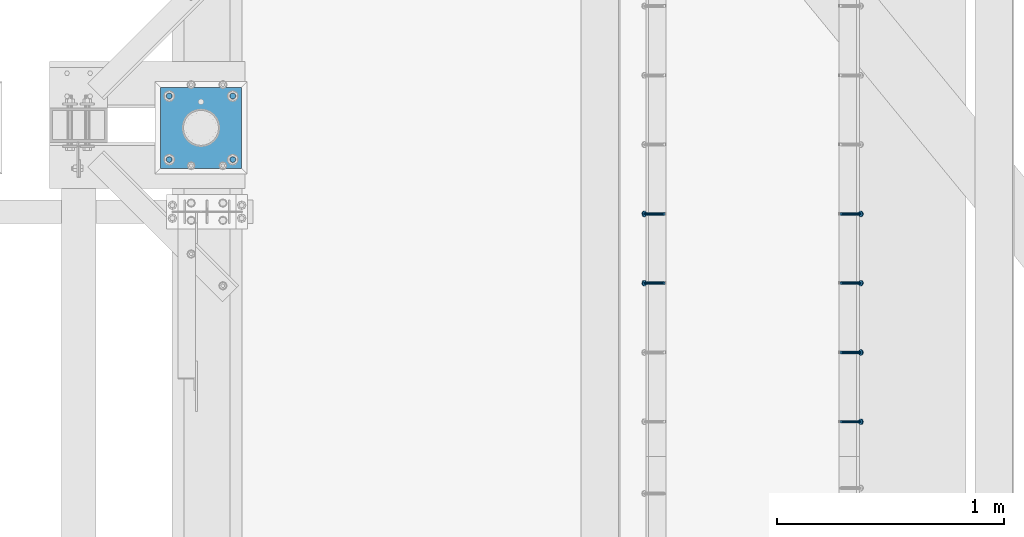
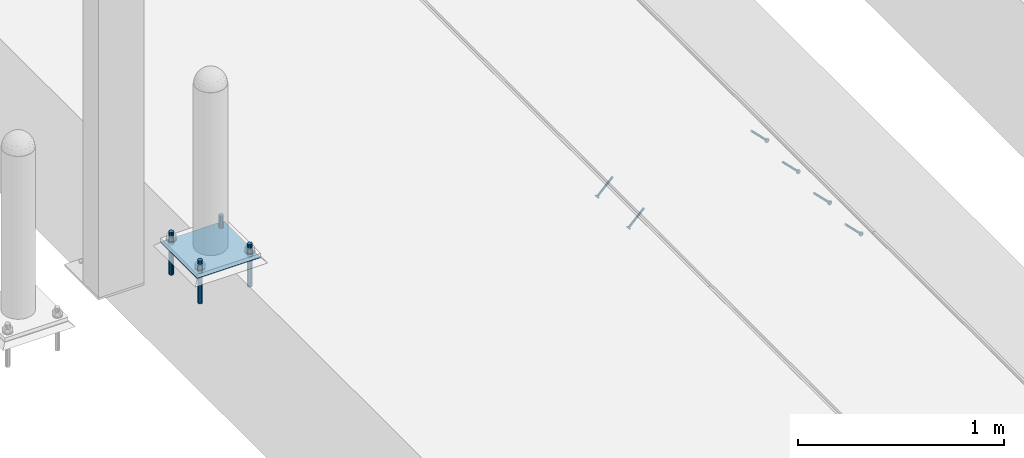
# One storey, part 2035 of 3843: 6 members, 5 beams, 3 elements without a shape of their own.
"""IFC2X3 building model written with IfcOpenShell, lengths in millimetres."""

from ifc_helpers import new_model, si_unit, frame, origin_with_axes, place, context, subcontext, project, spatial, faceted_brep, material, type_object, element, aggregate, save


model = new_model("IFC2X3")

# Units and contexts
model_context = context("Model", 3, precision=1e-05, world=origin_with_axes())
body_context = subcontext(model_context, "Body", "Model", "MODEL_VIEW")
ifc_project = project(units=[si_unit("LENGTHUNIT", "METRE", prefix="MILLI"), si_unit("AREAUNIT", "SQUARE_METRE"), si_unit("VOLUMEUNIT", "CUBIC_METRE"), si_unit("MASSUNIT", "GRAM", prefix="KILO"), si_unit("TIMEUNIT", "SECOND"), si_unit("PLANEANGLEUNIT", "RADIAN"), si_unit("SOLIDANGLEUNIT", "STERADIAN"), si_unit("THERMODYNAMICTEMPERATUREUNIT", "DEGREE_CELSIUS"), si_unit("LUMINOUSINTENSITYUNIT", "LUMEN")], contexts=[model_context])

# Site, building, storey
site_placement = place(None, origin_with_axes())
site = spatial("IfcSite", under=ifc_project, at=site_placement, CompositionType="ELEMENT")
building_placement = place(site_placement, origin_with_axes())
building = spatial("IfcBuilding", under=site, at=building_placement, Name="Undefined", CompositionType="ELEMENT")
storey_placement = place(building_placement, origin_with_axes())
storey = spatial("IfcBuildingStorey", under=building, at=storey_placement, Name="Undefined", CompositionType="ELEMENT", Elevation=0.0)

# Assembly, members
assembly_1_placement = place(storey_placement, origin_with_axes())
assembly_1 = element("IfcElementAssembly", 1, at=assembly_1_placement, inside=storey, Name="EMBED_ANGLE", AssemblyPlace="NOTDEFINED", PredefinedType="RIGID_FRAME")
ifc_material_1 = material(Name="STEEL/A108")
member_type = type_object("IfcMemberType", PredefinedType="NOTDEFINED")
member_1_placement = place(assembly_1_placement, frame((44851.3834999999, 28806.775189209, 30456.1875), z_axis=(0.0, 1.0, 0.0), x_axis=(0.707106781186548, 0.0, -0.707106781186548)))
member_1 = element("IfcMember", 2, at=member_1_placement, type_object=member_type, material=ifc_material_1, Name="HEADED STUD ANCHOR", context=body_context, shape_type="Brep", body=[
    faceted_brep([(7.27595761418343e-12, -3.18000006675175, 5.5), (0.0, -5.49999999998363, 3.1800000667572), (118.110000000976, -5.49999999999091, 3.1800000667572), (118.110000000983, -3.18000006675175, 5.5), (0.0, -6.3499999046162, 0.0), (118.110000000968, -6.34999990461256, 0.0), (0.0, -5.49999999998363, -3.1800000667572), (118.110000000976, -5.49999999999091, -3.1800000667572), (7.27595761418343e-12, -3.18000006675175, -5.5), (118.110000000983, -3.18000006675175, -5.5), (7.27595761418343e-12, -1.81898940354586e-12, -6.34999990463257), (118.110000000968, -1.81898940354586e-12, -6.34999990463257), (0.0, 3.18000006675175, -5.5), (118.110000000968, 3.18000006674811, -5.5), (7.27595761418343e-12, 5.49999999998363, -3.1800000667572), (118.110000000983, 5.49999999998363, -3.1800000667572), (7.27595761418343e-12, 6.3499999046162, 0.0), (118.110000000976, 6.34999990461256, 0.0), (7.27595761418343e-12, 5.49999999998363, 3.1800000667572), (118.110000000983, 5.49999999998363, 3.1800000667572), (0.0, 3.18000006675175, 5.5), (118.110000000968, 3.18000006674811, 5.5), (7.27595761418343e-12, -1.81898940354586e-12, 6.34999990463257), (118.110000000968, -1.81898940354586e-12, 6.34999990463257), (120.650000000991, -10.9899997710909, 6.34999990463257), (120.650000000998, -6.34000015257152, 10.9899997711182), (120.650000000991, -12.6999998092379, 0.0), (120.650000000991, -10.9899997710909, -6.34999990463257), (120.650000000998, -6.34000015257152, -10.9899997711182), (120.650000000991, -1.81898940354586e-12, -12.6899995803833), (120.650000000991, 6.34000015257152, -10.9899997711182), (120.650000000998, 10.9899997710909, -6.34999990463257), (120.650000000991, 12.6999998092342, 0.0), (120.650000000998, 10.9899997710909, 6.34999990463257), (120.650000000991, 6.34000015257152, 10.9899997711182), (120.650000000991, -1.81898940354586e-12, 12.6899995803833), (127.000000001048, -10.9899997710945, 6.34999990463257), (127.000000001048, -6.34000015257152, 10.9899997711182), (127.000000001048, -12.6999998092342, 0.0), (127.000000001048, -10.9899997710945, -6.34999990463257), (127.000000001048, -6.34000015257152, -10.9899997711182), (127.000000001048, 1.81898940354586e-12, -12.6899995803833), (127.000000001048, 6.34000015256788, -10.9899997711182), (127.000000001048, 10.9899997710909, -6.34999990463257), (127.000000001048, 12.6999998092379, 0.0), (127.000000001048, 10.9899997710909, 6.34999990463257), (127.000000001048, 6.34000015256788, 10.9899997711182), (127.000000001048, 1.81898940354586e-12, 12.6899995803833)], [[[0, 1, 2, 3]], [[1, 4, 5, 2]], [[4, 6, 7, 5]], [[6, 8, 9, 7]], [[8, 10, 11, 9]], [[10, 12, 13, 11]], [[12, 14, 15, 13]], [[14, 16, 17, 15]], [[16, 18, 19, 17]], [[18, 20, 21, 19]], [[20, 22, 23, 21]], [[22, 0, 3, 23]], [[22, 20, 18, 16, 14, 12, 10, 8, 6, 4, 1, 0]], [[3, 2, 24, 25]], [[2, 5, 26, 24]], [[5, 7, 27, 26]], [[7, 9, 28, 27]], [[9, 11, 29, 28]], [[11, 13, 30, 29]], [[13, 15, 31, 30]], [[15, 17, 32, 31]], [[17, 19, 33, 32]], [[19, 21, 34, 33]], [[21, 23, 35, 34]], [[23, 3, 25, 35]], [[25, 24, 36, 37]], [[24, 26, 38, 36]], [[26, 27, 39, 38]], [[27, 28, 40, 39]], [[28, 29, 41, 40]], [[29, 30, 42, 41]], [[30, 31, 43, 42]], [[31, 32, 44, 43]], [[32, 33, 45, 44]], [[33, 34, 46, 45]], [[34, 35, 47, 46]], [[35, 25, 37, 47]], [[38, 39, 40, 41, 42, 43, 44, 45, 46, 47, 37, 36]]]),
])
member_2_placement = place(assembly_1_placement, frame((44851.3834999999, 29111.575189209, 30456.1875), z_axis=(0.0, 1.0, 0.0), x_axis=(0.707106781186548, 0.0, -0.707106781186548)))
member_2 = element("IfcMember", 3, at=member_2_placement, type_object=member_type, material=ifc_material_1, Name="HEADED STUD ANCHOR", context=body_context, shape_type="Brep", body=[
    faceted_brep([(7.27595761418343e-12, -3.18000006675175, 5.5), (0.0, -5.49999999998363, 3.1800000667572), (118.110000000976, -5.49999999999091, 3.1800000667572), (118.110000000983, -3.18000006675175, 5.5), (0.0, -6.3499999046162, 0.0), (118.110000000968, -6.34999990461256, 0.0), (0.0, -5.49999999998363, -3.1800000667572), (118.110000000976, -5.49999999999091, -3.1800000667572), (7.27595761418343e-12, -3.18000006675175, -5.5), (118.110000000983, -3.18000006675175, -5.5), (7.27595761418343e-12, -1.81898940354586e-12, -6.34999990463257), (118.110000000968, -1.81898940354586e-12, -6.34999990463257), (0.0, 3.18000006675175, -5.5), (118.110000000968, 3.18000006674811, -5.5), (7.27595761418343e-12, 5.49999999998363, -3.1800000667572), (118.110000000983, 5.49999999998363, -3.1800000667572), (7.27595761418343e-12, 6.3499999046162, 0.0), (118.110000000976, 6.34999990461256, 0.0), (7.27595761418343e-12, 5.49999999998363, 3.1800000667572), (118.110000000983, 5.49999999998363, 3.1800000667572), (0.0, 3.18000006675175, 5.5), (118.110000000968, 3.18000006674811, 5.5), (7.27595761418343e-12, -1.81898940354586e-12, 6.34999990463257), (118.110000000968, -1.81898940354586e-12, 6.34999990463257), (120.650000000991, -10.9899997710909, 6.34999990463257), (120.650000000998, -6.34000015257152, 10.9899997711182), (120.650000000991, -12.6999998092379, 0.0), (120.650000000991, -10.9899997710909, -6.34999990463257), (120.650000000998, -6.34000015257152, -10.9899997711182), (120.650000000991, -1.81898940354586e-12, -12.6899995803833), (120.650000000991, 6.34000015257152, -10.9899997711182), (120.650000000998, 10.9899997710909, -6.34999990463257), (120.650000000991, 12.6999998092342, 0.0), (120.650000000998, 10.9899997710909, 6.34999990463257), (120.650000000991, 6.34000015257152, 10.9899997711182), (120.650000000991, -1.81898940354586e-12, 12.6899995803833), (127.000000001048, -10.9899997710945, 6.34999990463257), (127.000000001048, -6.34000015257152, 10.9899997711182), (127.000000001048, -12.6999998092342, 0.0), (127.000000001048, -10.9899997710945, -6.34999990463257), (127.000000001048, -6.34000015257152, -10.9899997711182), (127.000000001048, 1.81898940354586e-12, -12.6899995803833), (127.000000001048, 6.34000015256788, -10.9899997711182), (127.000000001048, 10.9899997710909, -6.34999990463257), (127.000000001048, 12.6999998092379, 0.0), (127.000000001048, 10.9899997710909, 6.34999990463257), (127.000000001048, 6.34000015256788, 10.9899997711182), (127.000000001048, 1.81898940354586e-12, 12.6899995803833)], [[[0, 1, 2, 3]], [[1, 4, 5, 2]], [[4, 6, 7, 5]], [[6, 8, 9, 7]], [[8, 10, 11, 9]], [[10, 12, 13, 11]], [[12, 14, 15, 13]], [[14, 16, 17, 15]], [[16, 18, 19, 17]], [[18, 20, 21, 19]], [[20, 22, 23, 21]], [[22, 0, 3, 23]], [[22, 20, 18, 16, 14, 12, 10, 8, 6, 4, 1, 0]], [[3, 2, 24, 25]], [[2, 5, 26, 24]], [[5, 7, 27, 26]], [[7, 9, 28, 27]], [[9, 11, 29, 28]], [[11, 13, 30, 29]], [[13, 15, 31, 30]], [[15, 17, 32, 31]], [[17, 19, 33, 32]], [[19, 21, 34, 33]], [[21, 23, 35, 34]], [[23, 3, 25, 35]], [[25, 24, 36, 37]], [[24, 26, 38, 36]], [[26, 27, 39, 38]], [[27, 28, 40, 39]], [[28, 29, 41, 40]], [[29, 30, 42, 41]], [[30, 31, 43, 42]], [[31, 32, 44, 43]], [[32, 33, 45, 44]], [[33, 34, 46, 45]], [[34, 35, 47, 46]], [[35, 25, 37, 47]], [[38, 39, 40, 41, 42, 43, 44, 45, 46, 47, 37, 36]]]),
])
member_3_placement = place(assembly_1_placement, frame((44851.3834999999, 29416.375189209, 30456.1875), z_axis=(0.0, 1.0, 0.0), x_axis=(0.707106781186548, 0.0, -0.707106781186548)))
member_3 = element("IfcMember", 4, at=member_3_placement, type_object=member_type, material=ifc_material_1, Name="HEADED STUD ANCHOR", context=body_context, shape_type="Brep", body=[
    faceted_brep([(7.27595761418343e-12, -3.18000006675175, 5.5), (0.0, -5.49999999998363, 3.1800000667572), (118.110000000976, -5.49999999999091, 3.1800000667572), (118.110000000983, -3.18000006675175, 5.5), (0.0, -6.3499999046162, 0.0), (118.110000000968, -6.34999990461256, 0.0), (0.0, -5.49999999998363, -3.1800000667572), (118.110000000976, -5.49999999999091, -3.1800000667572), (7.27595761418343e-12, -3.18000006675175, -5.5), (118.110000000983, -3.18000006675175, -5.5), (7.27595761418343e-12, -1.81898940354586e-12, -6.34999990463257), (118.110000000968, -1.81898940354586e-12, -6.34999990463257), (0.0, 3.18000006675175, -5.5), (118.110000000968, 3.18000006674811, -5.5), (7.27595761418343e-12, 5.49999999998363, -3.1800000667572), (118.110000000983, 5.49999999998363, -3.1800000667572), (7.27595761418343e-12, 6.3499999046162, 0.0), (118.110000000976, 6.34999990461256, 0.0), (7.27595761418343e-12, 5.49999999998363, 3.1800000667572), (118.110000000983, 5.49999999998363, 3.1800000667572), (0.0, 3.18000006675175, 5.5), (118.110000000968, 3.18000006674811, 5.5), (7.27595761418343e-12, -1.81898940354586e-12, 6.34999990463257), (118.110000000968, -1.81898940354586e-12, 6.34999990463257), (120.650000000991, -10.9899997710909, 6.34999990463257), (120.650000000998, -6.34000015257152, 10.9899997711182), (120.650000000991, -12.6999998092379, 0.0), (120.650000000991, -10.9899997710909, -6.34999990463257), (120.650000000998, -6.34000015257152, -10.9899997711182), (120.650000000991, -1.81898940354586e-12, -12.6899995803833), (120.650000000991, 6.34000015257152, -10.9899997711182), (120.650000000998, 10.9899997710909, -6.34999990463257), (120.650000000991, 12.6999998092342, 0.0), (120.650000000998, 10.9899997710909, 6.34999990463257), (120.650000000991, 6.34000015257152, 10.9899997711182), (120.650000000991, -1.81898940354586e-12, 12.6899995803833), (127.000000001048, -10.9899997710945, 6.34999990463257), (127.000000001048, -6.34000015257152, 10.9899997711182), (127.000000001048, -12.6999998092342, 0.0), (127.000000001048, -10.9899997710945, -6.34999990463257), (127.000000001048, -6.34000015257152, -10.9899997711182), (127.000000001048, 1.81898940354586e-12, -12.6899995803833), (127.000000001048, 6.34000015256788, -10.9899997711182), (127.000000001048, 10.9899997710909, -6.34999990463257), (127.000000001048, 12.6999998092379, 0.0), (127.000000001048, 10.9899997710909, 6.34999990463257), (127.000000001048, 6.34000015256788, 10.9899997711182), (127.000000001048, 1.81898940354586e-12, 12.6899995803833)], [[[0, 1, 2, 3]], [[1, 4, 5, 2]], [[4, 6, 7, 5]], [[6, 8, 9, 7]], [[8, 10, 11, 9]], [[10, 12, 13, 11]], [[12, 14, 15, 13]], [[14, 16, 17, 15]], [[16, 18, 19, 17]], [[18, 20, 21, 19]], [[20, 22, 23, 21]], [[22, 0, 3, 23]], [[22, 20, 18, 16, 14, 12, 10, 8, 6, 4, 1, 0]], [[3, 2, 24, 25]], [[2, 5, 26, 24]], [[5, 7, 27, 26]], [[7, 9, 28, 27]], [[9, 11, 29, 28]], [[11, 13, 30, 29]], [[13, 15, 31, 30]], [[15, 17, 32, 31]], [[17, 19, 33, 32]], [[19, 21, 34, 33]], [[21, 23, 35, 34]], [[23, 3, 25, 35]], [[25, 24, 36, 37]], [[24, 26, 38, 36]], [[26, 27, 39, 38]], [[27, 28, 40, 39]], [[28, 29, 41, 40]], [[29, 30, 42, 41]], [[30, 31, 43, 42]], [[31, 32, 44, 43]], [[32, 33, 45, 44]], [[33, 34, 46, 45]], [[34, 35, 47, 46]], [[35, 25, 37, 47]], [[38, 39, 40, 41, 42, 43, 44, 45, 46, 47, 37, 36]]]),
])
member_4_placement = place(assembly_1_placement, frame((44851.3834999999, 29721.175189209, 30456.1875), z_axis=(0.0, 1.0, 0.0), x_axis=(0.707106781186548, 0.0, -0.707106781186548)))
member_4 = element("IfcMember", 5, at=member_4_placement, type_object=member_type, material=ifc_material_1, Name="HEADED STUD ANCHOR", context=body_context, shape_type="Brep", body=[
    faceted_brep([(7.27595761418343e-12, -3.18000006675175, 5.5), (0.0, -5.49999999998363, 3.1800000667572), (118.110000000976, -5.49999999999091, 3.1800000667572), (118.110000000983, -3.18000006675175, 5.5), (0.0, -6.3499999046162, 0.0), (118.110000000968, -6.34999990461256, 0.0), (0.0, -5.49999999998363, -3.1800000667572), (118.110000000976, -5.49999999999091, -3.1800000667572), (7.27595761418343e-12, -3.18000006675175, -5.5), (118.110000000983, -3.18000006675175, -5.5), (7.27595761418343e-12, -1.81898940354586e-12, -6.34999990463257), (118.110000000968, -1.81898940354586e-12, -6.34999990463257), (0.0, 3.18000006675175, -5.5), (118.110000000968, 3.18000006674811, -5.5), (7.27595761418343e-12, 5.49999999998363, -3.1800000667572), (118.110000000983, 5.49999999998363, -3.1800000667572), (7.27595761418343e-12, 6.3499999046162, 0.0), (118.110000000976, 6.34999990461256, 0.0), (7.27595761418343e-12, 5.49999999998363, 3.1800000667572), (118.110000000983, 5.49999999998363, 3.1800000667572), (0.0, 3.18000006675175, 5.5), (118.110000000968, 3.18000006674811, 5.5), (7.27595761418343e-12, -1.81898940354586e-12, 6.34999990463257), (118.110000000968, -1.81898940354586e-12, 6.34999990463257), (120.650000000991, -10.9899997710909, 6.34999990463257), (120.650000000998, -6.34000015257152, 10.9899997711182), (120.650000000991, -12.6999998092379, 0.0), (120.650000000991, -10.9899997710909, -6.34999990463257), (120.650000000998, -6.34000015257152, -10.9899997711182), (120.650000000991, -1.81898940354586e-12, -12.6899995803833), (120.650000000991, 6.34000015257152, -10.9899997711182), (120.650000000998, 10.9899997710909, -6.34999990463257), (120.650000000991, 12.6999998092342, 0.0), (120.650000000998, 10.9899997710909, 6.34999990463257), (120.650000000991, 6.34000015257152, 10.9899997711182), (120.650000000991, -1.81898940354586e-12, 12.6899995803833), (127.000000001048, -10.9899997710945, 6.34999990463257), (127.000000001048, -6.34000015257152, 10.9899997711182), (127.000000001048, -12.6999998092342, 0.0), (127.000000001048, -10.9899997710945, -6.34999990463257), (127.000000001048, -6.34000015257152, -10.9899997711182), (127.000000001048, 1.81898940354586e-12, -12.6899995803833), (127.000000001048, 6.34000015256788, -10.9899997711182), (127.000000001048, 10.9899997710909, -6.34999990463257), (127.000000001048, 12.6999998092379, 0.0), (127.000000001048, 10.9899997710909, 6.34999990463257), (127.000000001048, 6.34000015256788, 10.9899997711182), (127.000000001048, 1.81898940354586e-12, 12.6899995803833)], [[[0, 1, 2, 3]], [[1, 4, 5, 2]], [[4, 6, 7, 5]], [[6, 8, 9, 7]], [[8, 10, 11, 9]], [[10, 12, 13, 11]], [[12, 14, 15, 13]], [[14, 16, 17, 15]], [[16, 18, 19, 17]], [[18, 20, 21, 19]], [[20, 22, 23, 21]], [[22, 0, 3, 23]], [[22, 20, 18, 16, 14, 12, 10, 8, 6, 4, 1, 0]], [[3, 2, 24, 25]], [[2, 5, 26, 24]], [[5, 7, 27, 26]], [[7, 9, 28, 27]], [[9, 11, 29, 28]], [[11, 13, 30, 29]], [[13, 15, 31, 30]], [[15, 17, 32, 31]], [[17, 19, 33, 32]], [[19, 21, 34, 33]], [[21, 23, 35, 34]], [[23, 3, 25, 35]], [[25, 24, 36, 37]], [[24, 26, 38, 36]], [[26, 27, 39, 38]], [[27, 28, 40, 39]], [[28, 29, 41, 40]], [[29, 30, 42, 41]], [[30, 31, 43, 42]], [[31, 32, 44, 43]], [[32, 33, 45, 44]], [[33, 34, 46, 45]], [[34, 35, 47, 46]], [[35, 25, 37, 47]], [[38, 39, 40, 41, 42, 43, 44, 45, 46, 47, 37, 36]]]),
])
aggregate(assembly_1, [member_1, member_2, member_3, member_4])

assembly_2_placement = place(storey_placement, origin_with_axes())
assembly_2 = element("IfcElementAssembly", 6, at=assembly_2_placement, inside=storey, Name="EMBED_ANGLE", AssemblyPlace="NOTDEFINED", PredefinedType="RIGID_FRAME")
member_5_placement = place(assembly_2_placement, frame((44073.5085000003, 29416.375189209, 30456.1874999998), z_axis=(0.0, -1.0, 0.0), x_axis=(-0.707106781186548, 0.0, -0.707106781186548)))
member_5 = element("IfcMember", 7, at=member_5_placement, type_object=member_type, material=ifc_material_1, Name="HEADED STUD ANCHOR", context=body_context, shape_type="Brep", body=[
    faceted_brep([(7.27595761418343e-12, -3.18000006675175, 5.5), (0.0, -5.49999999998363, 3.1800000667572), (118.110000000976, -5.49999999999091, 3.1800000667572), (118.110000000983, -3.18000006675175, 5.5), (0.0, -6.3499999046162, 0.0), (118.110000000968, -6.34999990461256, 0.0), (0.0, -5.49999999998363, -3.1800000667572), (118.110000000976, -5.49999999999091, -3.1800000667572), (7.27595761418343e-12, -3.18000006675175, -5.5), (118.110000000983, -3.18000006675175, -5.5), (7.27595761418343e-12, -1.81898940354586e-12, -6.34999990463257), (118.110000000968, -1.81898940354586e-12, -6.34999990463257), (0.0, 3.18000006675175, -5.5), (118.110000000968, 3.18000006674811, -5.5), (7.27595761418343e-12, 5.49999999998363, -3.1800000667572), (118.110000000983, 5.49999999998363, -3.1800000667572), (7.27595761418343e-12, 6.3499999046162, 0.0), (118.110000000976, 6.34999990461256, 0.0), (7.27595761418343e-12, 5.49999999998363, 3.1800000667572), (118.110000000983, 5.49999999998363, 3.1800000667572), (0.0, 3.18000006675175, 5.5), (118.110000000968, 3.18000006674811, 5.5), (7.27595761418343e-12, -1.81898940354586e-12, 6.34999990463257), (118.110000000968, -1.81898940354586e-12, 6.34999990463257), (120.650000000991, -10.9899997710909, 6.34999990463257), (120.650000000998, -6.34000015257152, 10.9899997711182), (120.650000000991, -12.6999998092379, 0.0), (120.650000000991, -10.9899997710909, -6.34999990463257), (120.650000000998, -6.34000015257152, -10.9899997711182), (120.650000000991, -1.81898940354586e-12, -12.6899995803833), (120.650000000991, 6.34000015257152, -10.9899997711182), (120.650000000998, 10.9899997710909, -6.34999990463257), (120.650000000991, 12.6999998092342, 0.0), (120.650000000998, 10.9899997710909, 6.34999990463257), (120.650000000991, 6.34000015257152, 10.9899997711182), (120.650000000991, -1.81898940354586e-12, 12.6899995803833), (127.000000001048, -10.9899997710945, 6.34999990463257), (127.000000001048, -6.34000015257152, 10.9899997711182), (127.000000001048, -12.6999998092342, 0.0), (127.000000001048, -10.9899997710945, -6.34999990463257), (127.000000001048, -6.34000015257152, -10.9899997711182), (127.000000001048, 1.81898940354586e-12, -12.6899995803833), (127.000000001048, 6.34000015256788, -10.9899997711182), (127.000000001048, 10.9899997710909, -6.34999990463257), (127.000000001048, 12.6999998092379, 0.0), (127.000000001048, 10.9899997710909, 6.34999990463257), (127.000000001048, 6.34000015256788, 10.9899997711182), (127.000000001048, 1.81898940354586e-12, 12.6899995803833)], [[[0, 1, 2, 3]], [[1, 4, 5, 2]], [[4, 6, 7, 5]], [[6, 8, 9, 7]], [[8, 10, 11, 9]], [[10, 12, 13, 11]], [[12, 14, 15, 13]], [[14, 16, 17, 15]], [[16, 18, 19, 17]], [[18, 20, 21, 19]], [[20, 22, 23, 21]], [[22, 0, 3, 23]], [[22, 20, 18, 16, 14, 12, 10, 8, 6, 4, 1, 0]], [[3, 2, 24, 25]], [[2, 5, 26, 24]], [[5, 7, 27, 26]], [[7, 9, 28, 27]], [[9, 11, 29, 28]], [[11, 13, 30, 29]], [[13, 15, 31, 30]], [[15, 17, 32, 31]], [[17, 19, 33, 32]], [[19, 21, 34, 33]], [[21, 23, 35, 34]], [[23, 3, 25, 35]], [[25, 24, 36, 37]], [[24, 26, 38, 36]], [[26, 27, 39, 38]], [[27, 28, 40, 39]], [[28, 29, 41, 40]], [[29, 30, 42, 41]], [[30, 31, 43, 42]], [[31, 32, 44, 43]], [[32, 33, 45, 44]], [[33, 34, 46, 45]], [[34, 35, 47, 46]], [[35, 25, 37, 47]], [[38, 39, 40, 41, 42, 43, 44, 45, 46, 47, 37, 36]]]),
])
member_6_placement = place(assembly_2_placement, frame((44073.5085000003, 29721.175189209, 30456.1874999998), z_axis=(0.0, -1.0, 0.0), x_axis=(-0.707106781186548, 0.0, -0.707106781186548)))
member_6 = element("IfcMember", 8, at=member_6_placement, type_object=member_type, material=ifc_material_1, Name="HEADED STUD ANCHOR", context=body_context, shape_type="Brep", body=[
    faceted_brep([(7.27595761418343e-12, -3.18000006675175, 5.5), (0.0, -5.49999999998363, 3.1800000667572), (118.110000000976, -5.49999999999091, 3.1800000667572), (118.110000000983, -3.18000006675175, 5.5), (0.0, -6.3499999046162, 0.0), (118.110000000968, -6.34999990461256, 0.0), (0.0, -5.49999999998363, -3.1800000667572), (118.110000000976, -5.49999999999091, -3.1800000667572), (7.27595761418343e-12, -3.18000006675175, -5.5), (118.110000000983, -3.18000006675175, -5.5), (7.27595761418343e-12, -1.81898940354586e-12, -6.34999990463257), (118.110000000968, -1.81898940354586e-12, -6.34999990463257), (0.0, 3.18000006675175, -5.5), (118.110000000968, 3.18000006674811, -5.5), (7.27595761418343e-12, 5.49999999998363, -3.1800000667572), (118.110000000983, 5.49999999998363, -3.1800000667572), (7.27595761418343e-12, 6.3499999046162, 0.0), (118.110000000976, 6.34999990461256, 0.0), (7.27595761418343e-12, 5.49999999998363, 3.1800000667572), (118.110000000983, 5.49999999998363, 3.1800000667572), (0.0, 3.18000006675175, 5.5), (118.110000000968, 3.18000006674811, 5.5), (7.27595761418343e-12, -1.81898940354586e-12, 6.34999990463257), (118.110000000968, -1.81898940354586e-12, 6.34999990463257), (120.650000000991, -10.9899997710909, 6.34999990463257), (120.650000000998, -6.34000015257152, 10.9899997711182), (120.650000000991, -12.6999998092379, 0.0), (120.650000000991, -10.9899997710909, -6.34999990463257), (120.650000000998, -6.34000015257152, -10.9899997711182), (120.650000000991, -1.81898940354586e-12, -12.6899995803833), (120.650000000991, 6.34000015257152, -10.9899997711182), (120.650000000998, 10.9899997710909, -6.34999990463257), (120.650000000991, 12.6999998092342, 0.0), (120.650000000998, 10.9899997710909, 6.34999990463257), (120.650000000991, 6.34000015257152, 10.9899997711182), (120.650000000991, -1.81898940354586e-12, 12.6899995803833), (127.000000001048, -10.9899997710945, 6.34999990463257), (127.000000001048, -6.34000015257152, 10.9899997711182), (127.000000001048, -12.6999998092342, 0.0), (127.000000001048, -10.9899997710945, -6.34999990463257), (127.000000001048, -6.34000015257152, -10.9899997711182), (127.000000001048, 1.81898940354586e-12, -12.6899995803833), (127.000000001048, 6.34000015256788, -10.9899997711182), (127.000000001048, 10.9899997710909, -6.34999990463257), (127.000000001048, 12.6999998092379, 0.0), (127.000000001048, 10.9899997710909, 6.34999990463257), (127.000000001048, 6.34000015256788, 10.9899997711182), (127.000000001048, 1.81898940354586e-12, 12.6899995803833)], [[[0, 1, 2, 3]], [[1, 4, 5, 2]], [[4, 6, 7, 5]], [[6, 8, 9, 7]], [[8, 10, 11, 9]], [[10, 12, 13, 11]], [[12, 14, 15, 13]], [[14, 16, 17, 15]], [[16, 18, 19, 17]], [[18, 20, 21, 19]], [[20, 22, 23, 21]], [[22, 0, 3, 23]], [[22, 20, 18, 16, 14, 12, 10, 8, 6, 4, 1, 0]], [[3, 2, 24, 25]], [[2, 5, 26, 24]], [[5, 7, 27, 26]], [[7, 9, 28, 27]], [[9, 11, 29, 28]], [[11, 13, 30, 29]], [[13, 15, 31, 30]], [[15, 17, 32, 31]], [[17, 19, 33, 32]], [[19, 21, 34, 33]], [[21, 23, 35, 34]], [[23, 3, 25, 35]], [[25, 24, 36, 37]], [[24, 26, 38, 36]], [[26, 27, 39, 38]], [[27, 28, 40, 39]], [[28, 29, 41, 40]], [[29, 30, 42, 41]], [[30, 31, 43, 42]], [[31, 32, 44, 43]], [[32, 33, 45, 44]], [[33, 34, 46, 45]], [[34, 35, 47, 46]], [[35, 25, 37, 47]], [[38, 39, 40, 41, 42, 43, 44, 45, 46, 47, 37, 36]]]),
])
aggregate(assembly_2, [member_5, member_6])

# Assembly, beams
assembly_3_placement = place(storey_placement, origin_with_axes())
assembly_3 = element("IfcElementAssembly", 9, at=assembly_3_placement, inside=storey, Name="TEMPLATE", AssemblyPlace="NOTDEFINED", PredefinedType="RIGID_FRAME")
ifc_material_2 = material(Name="STEEL/316 SS")
beam_type_1 = type_object("IfcBeamType", PredefinedType="NOTDEFINED")
beam_1_placement = place(assembly_3_placement, frame((42175.476550293, 29960.0152178551, 30581.6), z_axis=(1.0, 0.0, 0.0), x_axis=(0.0, 0.0, -1.0)))
beam_1 = element("IfcBeam", 10, at=beam_1_placement, type_object=beam_type_1, material=ifc_material_2, Name="ANCHOR_ROD", context=body_context, shape_type="Brep", body=[
    faceted_brep([(0.0, -12.6999999999971, 0.0), (0.0, -10.9985226280696, -6.34999999999854), (253.999, -10.9985226280696, -6.34999999999854), (253.999, -12.6999999999971, 0.0), (0.0, -6.35000000000582, -10.9985226280623), (253.999, -6.35000000000582, -10.9985226280623), (0.0, 0.0, -12.6999999999971), (253.999, 0.0, -12.6999999999971), (0.0, 6.35000000000582, -10.9985226280623), (253.999, 6.35000000000582, -10.9985226280623), (0.0, 10.9985226280696, -6.34999999999854), (253.999, 10.9985226280696, -6.34999999999854), (0.0, 12.6999999999971, 0.0), (253.999, 12.6999999999971, 0.0), (0.0, 10.9985226280696, 6.34999999999854), (253.999, 10.9985226280696, 6.34999999999854), (0.0, 6.35000000000582, 10.9985226280623), (253.999, 6.35000000000582, 10.9985226280623), (0.0, 0.0, 12.6999999999971), (253.999, 0.0, 12.6999999999971), (0.0, -6.35000000000582, 10.9985226280623), (253.999, -6.35000000000582, 10.9985226280623), (0.0, -10.9985226280696, 6.34999999999854), (253.999, -10.9985226280696, 6.34999999999854)], [[[0, 1, 2, 3]], [[1, 4, 5, 2]], [[4, 6, 7, 5]], [[6, 8, 9, 7]], [[8, 10, 11, 9]], [[10, 12, 13, 11]], [[12, 14, 15, 13]], [[14, 16, 17, 15]], [[16, 18, 19, 17]], [[18, 20, 21, 19]], [[20, 22, 23, 21]], [[22, 0, 3, 23]], [[5, 7, 9, 11, 13, 15, 17, 19, 21, 23, 3, 2]], [[22, 20, 18, 16, 14, 12, 10, 8, 6, 4, 1, 0]]]),
])
beam_2_placement = place(assembly_3_placement, frame((42175.476550293, 30239.4152178551, 30581.6), z_axis=(-1.0, 0.0, 0.0), x_axis=(0.0, 0.0, -1.0)))
beam_2 = element("IfcBeam", 11, at=beam_2_placement, type_object=beam_type_1, material=ifc_material_2, Name="ANCHOR_ROD", context=body_context, shape_type="Brep", body=[
    faceted_brep([(0.0, -12.6999999999971, 0.0), (0.0, -10.9985226280696, -6.34999999999854), (253.999, -10.9985226280696, -6.34999999999854), (253.999, -12.6999999999971, 0.0), (0.0, -6.35000000000582, -10.9985226280623), (253.999, -6.35000000000582, -10.9985226280623), (0.0, 0.0, -12.6999999999971), (253.999, 0.0, -12.6999999999971), (0.0, 6.35000000000582, -10.9985226280623), (253.999, 6.35000000000582, -10.9985226280623), (0.0, 10.9985226280696, -6.34999999999854), (253.999, 10.9985226280696, -6.34999999999854), (0.0, 12.6999999999971, 0.0), (253.999, 12.6999999999971, 0.0), (0.0, 10.9985226280696, 6.34999999999854), (253.999, 10.9985226280696, 6.34999999999854), (0.0, 6.35000000000582, 10.9985226280623), (253.999, 6.35000000000582, 10.9985226280623), (0.0, 0.0, 12.6999999999971), (253.999, 0.0, 12.6999999999971), (0.0, -6.35000000000582, 10.9985226280623), (253.999, -6.35000000000582, 10.9985226280623), (0.0, -10.9985226280696, 6.34999999999854), (253.999, -10.9985226280696, 6.34999999999854)], [[[0, 1, 2, 3]], [[1, 4, 5, 2]], [[4, 6, 7, 5]], [[6, 8, 9, 7]], [[8, 10, 11, 9]], [[10, 12, 13, 11]], [[12, 14, 15, 13]], [[14, 16, 17, 15]], [[16, 18, 19, 17]], [[18, 20, 21, 19]], [[20, 22, 23, 21]], [[22, 0, 3, 23]], [[5, 7, 9, 11, 13, 15, 17, 19, 21, 23, 3, 2]], [[22, 20, 18, 16, 14, 12, 10, 8, 6, 4, 1, 0]]]),
])
beam_3_placement = place(assembly_3_placement, frame((41896.076550293, 29960.0152178551, 30581.6), z_axis=(1.0, 0.0, 0.0), x_axis=(0.0, 0.0, -1.0)))
beam_3 = element("IfcBeam", 12, at=beam_3_placement, type_object=beam_type_1, material=ifc_material_2, Name="ANCHOR_ROD", context=body_context, shape_type="Brep", body=[
    faceted_brep([(0.0, -12.6999999999971, 0.0), (0.0, -10.9985226280696, -6.34999999999854), (253.999, -10.9985226280696, -6.34999999999854), (253.999, -12.6999999999971, 0.0), (0.0, -6.35000000000582, -10.9985226280623), (253.999, -6.35000000000582, -10.9985226280623), (0.0, 0.0, -12.6999999999971), (253.999, 0.0, -12.6999999999971), (0.0, 6.35000000000582, -10.9985226280623), (253.999, 6.35000000000582, -10.9985226280623), (0.0, 10.9985226280696, -6.34999999999854), (253.999, 10.9985226280696, -6.34999999999854), (0.0, 12.6999999999971, 0.0), (253.999, 12.6999999999971, 0.0), (0.0, 10.9985226280696, 6.34999999999854), (253.999, 10.9985226280696, 6.34999999999854), (0.0, 6.35000000000582, 10.9985226280623), (253.999, 6.35000000000582, 10.9985226280623), (0.0, 0.0, 12.6999999999971), (253.999, 0.0, 12.6999999999971), (0.0, -6.35000000000582, 10.9985226280623), (253.999, -6.35000000000582, 10.9985226280623), (0.0, -10.9985226280696, 6.34999999999854), (253.999, -10.9985226280696, 6.34999999999854)], [[[0, 1, 2, 3]], [[1, 4, 5, 2]], [[4, 6, 7, 5]], [[6, 8, 9, 7]], [[8, 10, 11, 9]], [[10, 12, 13, 11]], [[12, 14, 15, 13]], [[14, 16, 17, 15]], [[16, 18, 19, 17]], [[18, 20, 21, 19]], [[20, 22, 23, 21]], [[22, 0, 3, 23]], [[5, 7, 9, 11, 13, 15, 17, 19, 21, 23, 3, 2]], [[22, 20, 18, 16, 14, 12, 10, 8, 6, 4, 1, 0]]]),
])
beam_4_placement = place(assembly_3_placement, frame((41896.076550293, 30239.4152178551, 30581.6), z_axis=(-1.0, 0.0, 0.0), x_axis=(0.0, 0.0, -1.0)))
beam_4 = element("IfcBeam", 13, at=beam_4_placement, type_object=beam_type_1, material=ifc_material_2, Name="ANCHOR_ROD", context=body_context, shape_type="Brep", body=[
    faceted_brep([(0.0, -12.6999999999971, 0.0), (0.0, -10.9985226280696, -6.34999999999854), (253.999, -10.9985226280696, -6.34999999999854), (253.999, -12.6999999999971, 0.0), (0.0, -6.35000000000582, -10.9985226280623), (253.999, -6.35000000000582, -10.9985226280623), (0.0, 0.0, -12.6999999999971), (253.999, 0.0, -12.6999999999971), (0.0, 6.35000000000582, -10.9985226280623), (253.999, 6.35000000000582, -10.9985226280623), (0.0, 10.9985226280696, -6.34999999999854), (253.999, 10.9985226280696, -6.34999999999854), (0.0, 12.6999999999971, 0.0), (253.999, 12.6999999999971, 0.0), (0.0, 10.9985226280696, 6.34999999999854), (253.999, 10.9985226280696, 6.34999999999854), (0.0, 6.35000000000582, 10.9985226280623), (253.999, 6.35000000000582, 10.9985226280623), (0.0, 0.0, 12.6999999999971), (253.999, 0.0, 12.6999999999971), (0.0, -6.35000000000582, 10.9985226280623), (253.999, -6.35000000000582, 10.9985226280623), (0.0, -10.9985226280696, 6.34999999999854), (253.999, -10.9985226280696, 6.34999999999854)], [[[0, 1, 2, 3]], [[1, 4, 5, 2]], [[4, 6, 7, 5]], [[6, 8, 9, 7]], [[8, 10, 11, 9]], [[10, 12, 13, 11]], [[12, 14, 15, 13]], [[14, 16, 17, 15]], [[16, 18, 19, 17]], [[18, 20, 21, 19]], [[20, 22, 23, 21]], [[22, 0, 3, 23]], [[5, 7, 9, 11, 13, 15, 17, 19, 21, 23, 3, 2]], [[22, 20, 18, 16, 14, 12, 10, 8, 6, 4, 1, 0]]]),
])
ifc_material_3 = material(Name="STEEL/A36")
beam_type_2 = type_object("IfcBeamType", PredefinedType="NOTDEFINED")
beam_5_placement = place(assembly_3_placement, frame((42213.576550293, 30099.7152178551, 30506.9875), z_axis=(0.0, -1.0, 0.0), x_axis=(-1.0, 0.0, 0.0)))
beam_5 = element("IfcBeam", 14, at=beam_5_placement, type_object=beam_type_2, material=ifc_material_3, Name="TEMPLATE", context=body_context, shape_type="Brep", body=[
    faceted_brep([(0.0, 1.58750000000146, -177.800000000003), (0.0, 1.58750000000146, 177.800000000003), (355.600000000006, 1.58750000000146, 177.800000000003), (355.600000000006, 1.58750000000146, -177.800000000003), (0.0, -1.58750000000146, 177.800000000003), (355.600000000006, -1.58750000000146, 177.800000000003), (0.0, -1.58750000000146, -177.800000000003), (355.600000000006, -1.58750000000146, -177.800000000003)], [[[0, 1, 2, 3]], [[1, 4, 5, 2]], [[4, 6, 7, 5]], [[6, 0, 3, 7]], [[5, 7, 3, 2]], [[6, 4, 1, 0]]]),
])
aggregate(assembly_3, [beam_1, beam_2, beam_3, beam_4, beam_5])

save(model, "model.ifc")
